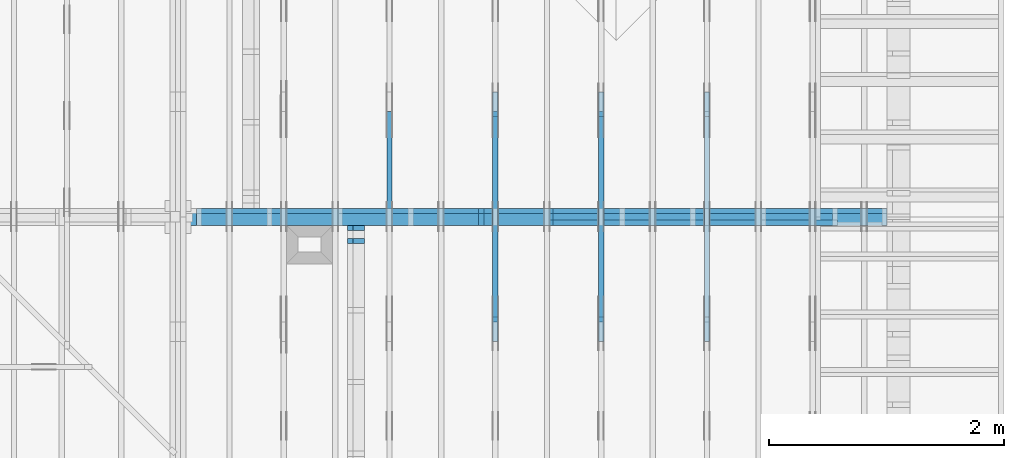
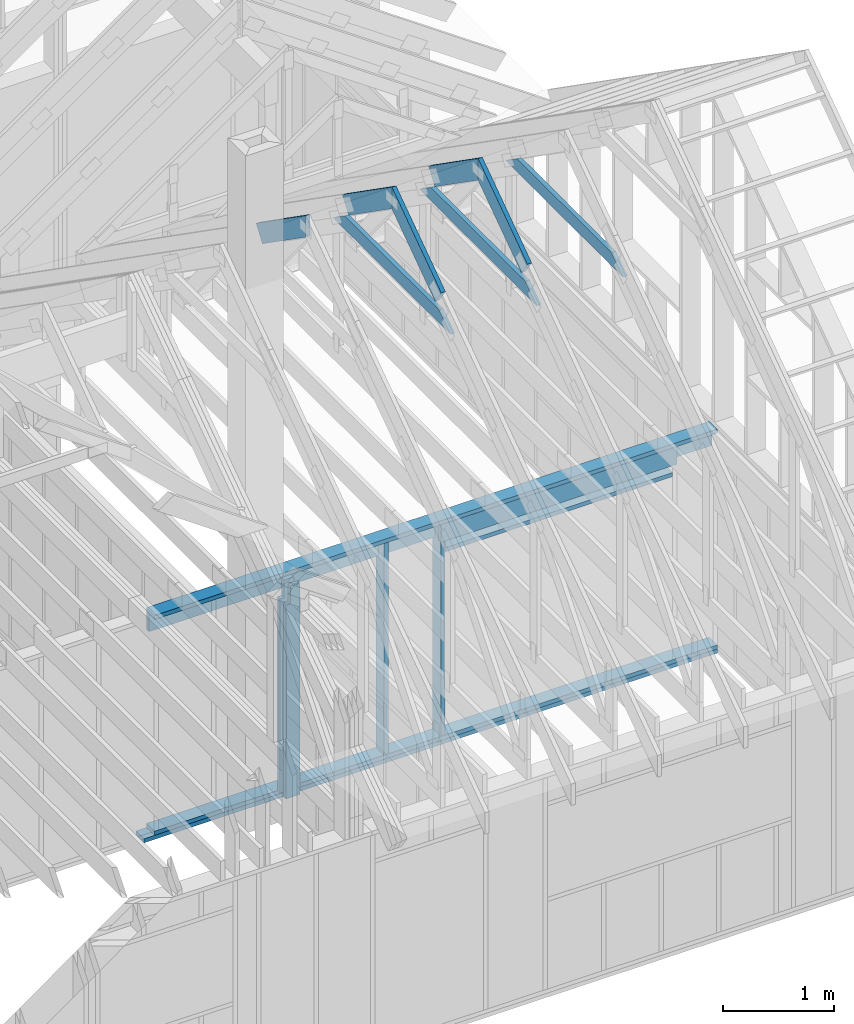
# One storey, part 24 of 70: 18 members, 6 elements without a shape of their own.
"""IFC2X3 building model written with IfcOpenShell, lengths in millimetres."""

from ifc_helpers import new_model, si_unit, frame, origin, origin_with_axes, origin_2d, place, context, project, spatial, faceted_brep, element, aggregate, save


model = new_model("IFC2X3")

# Units and contexts
model_context = context("Model", 3, precision=1e-05, world=origin())
plan_context = context("Plan", 2, precision=1e-05, world=origin_2d())
ifc_project = project(units=[si_unit("LENGTHUNIT", "METRE", prefix="MILLI"), si_unit("AREAUNIT", "SQUARE_METRE"), si_unit("VOLUMEUNIT", "CUBIC_METRE"), si_unit("SOLIDANGLEUNIT", "STERADIAN"), si_unit("PLANEANGLEUNIT", "RADIAN"), si_unit("MASSUNIT", "GRAM"), si_unit("TIMEUNIT", "SECOND"), si_unit("THERMODYNAMICTEMPERATUREUNIT", "DEGREE_CELSIUS"), si_unit("LUMINOUSINTENSITYUNIT", "LUMEN")], contexts=[model_context, plan_context])

# Site, building, storey
site_placement = place(None, origin_with_axes())
site = spatial("IfcSite", under=ifc_project, at=site_placement, CompositionType="ELEMENT")
building_placement = place(site_placement, origin_with_axes())
building = spatial("IfcBuilding", under=site, at=building_placement, Name="Layout 1", CompositionType="ELEMENT")
storey_placement = place(building_placement, origin_with_axes())
storey = spatial("IfcBuildingStorey", under=building, at=storey_placement, Name="Storey 1", CompositionType="ELEMENT", Elevation=0.0)

# Assembly, members
assembly_1_placement = place(storey_placement, frame((-48.55339059327651, 3927.500000000001, -2470.0), z_axis=(0.0, -1.0, 6.123031769111886e-17), x_axis=(1.0, 0.0, 0.0)))
assembly_1 = element("IfcElementAssembly", 1, at=assembly_1_placement, inside=storey, Name="VE8", AssemblyPlace="FACTORY", PredefinedType="NOTDEFINED")
member_1_placement = place(assembly_1_placement, frame((5979.999999999998, 2425.0, -145.0), z_axis=(0.0, 0.0, 1.0), x_axis=(1.0, 0.0, 0.0)))
member_1 = element("IfcMember", 2, at=member_1_placement, Name="P14", context=model_context, shape_type="Brep", body=[
    faceted_brep([(5873.553390593279, 45.0, 145.0), (0.0, 45.0, 145.0), (0.0, 0.0, 145.0), (5873.553390593279, 0.0, 145.0), (0.0, 45.0, 0.0), (5873.553390593279, 45.0, 7.192790801635497e-13), (5873.553390593279, 0.0, 7.192790801635497e-13), (0.0, 0.0, 0.0), (0.0, 0.0, 0.0), (8.878396065212235e-15, -1.0872540233210496e-30, 145.0), (1.4389124657412933e-14, 45.0, 145.0), (5.510728592200698e-15, 45.0, -3.3742366240998092e-31), (5873.553390593279, -1.0789186202453245e-12, 6.606252988048485e-29), (5873.553390593279, -1.0700402241801122e-12, 145.0), (1.6308810349815745e-30, 8.878396065212235e-15, 145.0), (0.0, 0.0, 0.0), (5873.553390593279, 45.0, 0.0), (5873.553390593279, 45.0, 145.0), (5873.553390593279, 0.0, 145.0), (5873.553390593279, 0.0, 0.0), (0.0, 45.0, 0.0), (-5.436270116605248e-31, 44.99999999999999, 145.0), (5873.553390593279, 44.99999999999963, 145.0), (5873.553390593279, 44.99999999999964, -2.208810534618833e-29)], [[[0, 1, 2, 3]], [[4, 5, 6, 7]], [[8, 9, 10, 11]], [[12, 13, 14, 15]], [[16, 17, 18, 19]], [[20, 21, 22, 23]]]),
])
member_2_placement = place(assembly_1_placement, frame((11853.553390593277, 90.0, -145.0), z_axis=(0.0, 0.0, 1.0), x_axis=(-1.0, 1.2246063538223773e-16, 0.0)))
member_2 = element("IfcMember", 3, at=member_2_placement, Name="P14", context=model_context, shape_type="Brep", body=[
    faceted_brep([(5873.553390593278, 45.00000000000072, 145.0), (0.0, 45.00000000000072, 145.0), (0.0, 0.0, 145.0), (5873.553390593278, 0.0, 145.0), (0.0, 45.00000000000072, 0.0), (5873.553390593278, 45.00000000000072, 7.192790801635496e-13), (5873.553390593278, 0.0, 7.192790801635496e-13), (0.0, 0.0, 0.0), (0.0, 0.0, 0.0), (8.878396065212235e-15, -1.0872540233210496e-30, 145.0), (1.4389124657412933e-14, 45.0, 145.0), (5.510728592200698e-15, 45.0, -3.3742366240998092e-31), (5873.553390593278, -1.0789186202453243e-12, 1.095692873241925e-28), (5873.553390593278, -1.070040224180112e-12, 145.0), (1.6308810349815745e-30, 8.878396065212235e-15, 145.0), (0.0, 0.0, 0.0), (5873.553390593278, 45.00000000000072, 0.0), (5873.553390593278, 45.00000000000072, 145.0), (5873.553390593278, 7.105427357601002e-13, 145.0), (5873.553390593278, 7.105427357601002e-13, 0.0), (0.0, 45.0, 0.0), (1.5777218104420236e-30, 44.99999999999999, 145.0), (5873.553390593278, 45.00000000000094, 145.0), (5873.553390593278, 45.000000000000945, 1.4199496293978212e-29)], [[[0, 1, 2, 3]], [[4, 5, 6, 7]], [[8, 9, 10, 11]], [[12, 13, 14, 15]], [[16, 17, 18, 19]], [[20, 21, 22, 23]]]),
])
member_3_placement = place(assembly_1_placement, frame((5979.999999999998, 2230.0, -145.0), z_axis=(0.0, 0.0, 1.0), x_axis=(1.0, 0.0, 0.0)))
member_3 = element("IfcMember", 4, at=member_3_placement, Name="L2", context=model_context, shape_type="Brep", body=[
    faceted_brep([(5873.553390593279, 195.0, 45.0), (0.0, 195.0, 45.0), (0.0, 0.0, 45.0), (5873.553390593279, 0.0, 45.0), (0.0, 195.0, 0.0), (5873.553390593279, 195.0, 7.192790801635497e-13), (5873.553390593279, 0.0, 7.192790801635497e-13), (0.0, 0.0, 0.0), (0.0, 0.0, 0.0), (2.755364296100349e-15, -3.3742366240998092e-31, 45.0), (2.6635188195636705e-14, 195.0, 45.0), (2.3879823899536357e-14, 195.0, -1.462169203776584e-30), (5873.553390593279, -1.0789186202453245e-12, 6.606252988048485e-29), (5873.553390593279, -1.0761632559492241e-12, 45.0), (5.061354936149714e-31, 2.755364296100349e-15, 45.0), (0.0, 0.0, 0.0), (5873.553390593279, 195.0, 0.0), (5873.553390593279, 195.0, 45.0), (5873.553390593279, 0.0, 45.0), (5873.553390593279, 0.0, 0.0), (0.0, 195.0, 0.0), (-1.6871183120499046e-31, 195.0, 45.0), (5873.553390593279, 194.99999999999963, 45.0), (5873.553390593279, 194.99999999999963, -2.208810534618833e-29)], [[[0, 1, 2, 3]], [[4, 5, 6, 7]], [[8, 9, 10, 11]], [[12, 13, 14, 15]], [[16, 17, 18, 19]], [[20, 21, 22, 23]]]),
])
member_4_placement = place(assembly_1_placement, frame((11853.553390593277, 45.0, -145.0), z_axis=(0.0, 0.0, 1.0), x_axis=(-1.0, 1.2246063538223773e-16, 0.0)))
member_4 = element("IfcMember", 5, at=member_4_placement, Name="P13", context=model_context, shape_type="Brep", body=[
    faceted_brep([(5980.000000000001, 45.00000000000001, 145.0), (0.0, 45.00000000000001, 145.0), (0.0, 0.0, 145.0), (5980.000000000001, 0.0, 145.0), (0.0, 45.00000000000001, 0.0), (5980.000000000001, 45.00000000000001, 7.323145995857817e-13), (5980.000000000001, 0.0, 7.323145995857817e-13), (0.0, 0.0, 0.0), (0.0, 0.0, 0.0), (8.878396065212235e-15, -1.0872540233210496e-30, 145.0), (1.4389124657641033e-14, 45.000000001862645, 145.0), (5.510728592428798e-15, 45.000000001862645, -3.3742366242394762e-31), (5980.000000000001, -1.0984718993786726e-12, 6.725978337372288e-29), (5980.000000000001, -1.0895935033134604e-12, 145.0), (1.6308810349815745e-30, 8.878396065212235e-15, 145.0), (0.0, 0.0, 0.0), (5980.000000000001, 45.00000000000001, 0.0), (5980.000000000001, 45.00000000000001, 145.0), (5980.000000000001, 0.0, 145.0), (5980.000000000001, 0.0, 0.0), (0.0, 45.000000001862645, 0.0), (-3.2311742677852644e-27, 45.00000000186264, 145.0), (5980.000000000001, 45.000000000000654, 145.0), (5980.000000000001, 45.00000000000067, 4.02319061662716e-29)], [[[0, 1, 2, 3]], [[4, 5, 6, 7]], [[8, 9, 10, 11]], [[12, 13, 14, 15]], [[16, 17, 18, 19]], [[20, 21, 22, 23]]]),
])
member_5_placement = place(assembly_1_placement, frame((8377.500000001819, 2425.0, -145.0), z_axis=(0.0, 0.0, 1.0), x_axis=(-1.836909530733566e-16, -1.0, 0.0)))
member_5 = element("IfcMember", 6, at=member_5_placement, Name="S42", context=model_context, shape_type="Brep", body=[
    faceted_brep([(0.0, 45.000000000029104, 45.0), (195.00000000186265, 45.000000000029104, 45.00000000000002), (195.00000000186265, 1.4551915228366852e-11, 45.00000000000002), (0.0, 1.4551915228366852e-11, 45.0), (195.00000000186265, 1.2732925824820995e-11, 0.0), (195.00000000186265, 1.2732925824820995e-11, 45.0), (195.00000000186265, 45.000000000027285, 45.0), (195.00000000186265, 45.000000000027285, 0.0), (2.755364296102131e-15, 1.4551915228366852e-11, 45.0), (8.878396065214018e-15, 1.4551915228366852e-11, 145.0), (1.43891246574165e-14, 45.000000000029104, 145.0), (8.26609288830461e-15, 45.000000000029104, 45.0), (2335.0, 1.4122996852940564e-11, 2.626280839091018e-29), (2335.0, 1.4131875249005776e-11, 145.0), (1.6308810349815745e-30, 1.4560793624432064e-11, 145.0), (5.061354936149714e-31, 1.4554670592662952e-11, 45.0), (195.00000000186265, 1.4518850856813305e-11, 45.0), (195.00000000186265, 1.4516095492517205e-11, 2.193253805685862e-30), (-1.6871183120499046e-31, 45.000000000027285, 45.0), (-5.436270116605248e-31, 45.00000000002728, 145.0), (2335.0, 45.000000000027136, 145.0), (2335.0, 45.00000000002714, -8.67746995743113e-30), (195.00000000186265, 45.00000000002727, -7.888609052210118e-31), (195.00000000186265, 45.00000000002727, 45.0), (2335.0, 45.00000000001455, 2.842170943040401e-14), (2335.0, 45.00000000001455, 145.0), (2335.0, 0.0, 145.0), (2335.0, 0.0, 2.842170943040401e-14), (2335.0, 45.00000000001455, 145.0), (0.0, 45.00000000001455, 145.0), (0.0, 1.4551915228366852e-11, 145.0), (2335.0, 1.4551915228366852e-11, 145.0), (195.00000000186265, 45.000000000027285, 2.3879823899764457e-14), (2335.0, 45.000000000027285, 2.859455836175251e-13), (2335.0, 0.0, 2.859455836175251e-13), (195.00000000186265, 0.0, 2.3879823899764457e-14)], [[[0, 1, 2, 3]], [[4, 5, 6, 7]], [[8, 9, 10, 11]], [[12, 13, 14, 15, 16, 17]], [[18, 19, 20, 21, 22, 23]], [[24, 25, 26, 27]], [[28, 29, 30, 31]], [[32, 33, 34, 35]]]),
])
member_6_placement = place(assembly_1_placement, frame((8967.500000003638, 2230.0, -45.0), z_axis=(0.0, 0.0, 1.0), x_axis=(1.0, 0.0, 0.0)))
member_6 = element("IfcMember", 7, at=member_6_placement, Name="L7", context=model_context, shape_type="Brep", body=[
    faceted_brep([(2465.0000000000437, 195.0, 45.0), (0.0, 195.0, 45.0), (1.8189894035458565e-12, 0.0, 45.0), (2465.000000000042, 0.0, 45.0), (0.0, 195.0, 0.0), (2465.0000000000437, 195.0, 3.0186546621722135e-13), (2465.000000000042, 0.0, 3.018654662172211e-13), (1.8189894035458565e-12, 0.0, 2.227545981117832e-28), (1.8189894035458565e-12, 0.0, 0.0), (1.821744767841957e-12, 2.5358754952779855e-29, 45.0), (2.7079277405486768e-14, 195.0, 45.0), (2.432391310938642e-14, 195.0, -1.4893609271789013e-30), (2465.000000000042, -4.5279819932583167e-13, 2.7724977594687237e-29), (2465.000000000042, -4.500428350297313e-13, 45.0), (1.8189894035458565e-12, 2.7553642961000147e-15, 45.0), (1.8189894035458565e-12, -3.341318971676748e-28, 2.0459002214312988e-44), (2465.000000000042, 195.0, -1.262177448353619e-28), (2465.000000000042, 195.0, 45.0), (2465.000000000042, 0.0, 45.0), (2465.000000000042, 0.0, 0.0), (0.0, 195.0, 0.0), (-1.6871183120499046e-31, 195.0, 45.0), (2465.0000000000437, 194.99999999999986, 45.0), (2465.0000000000437, 194.99999999999986, -9.466330862652142e-30)], [[[0, 1, 2, 3]], [[4, 5, 6, 7]], [[8, 9, 10, 11]], [[12, 13, 14, 15]], [[16, 17, 18, 19]], [[20, 21, 22, 23]]]),
])
member_7_placement = place(assembly_1_placement, frame((8967.500000003638, 2425.0, -145.0), z_axis=(0.0, 0.0, 1.0), x_axis=(-1.836909530733566e-16, -1.0, 0.0)))
member_7 = element("IfcMember", 8, at=member_7_placement, Name="S43", context=model_context, shape_type="Brep", body=[
    faceted_brep([(195.0, 1.8189894035458565e-12, 1.14050354233233e-25), (195.0, 1.8189894035458565e-12, 45.0), (195.0, 45.00000000001455, 45.0), (195.0, 45.00000000001455, 1.14050354233233e-25), (195.0, 1.8189894035458565e-12, 100.0), (195.0, 1.8189894035458565e-12, 145.0), (195.00000000000003, 45.00000000001455, 145.0), (195.0, 45.00000000001455, 100.0), (195.0, 45.00000000001455, 100.0), (0.0, 45.00000000001455, 100.0), (0.0, 1.8189894035458565e-12, 100.0), (195.0, 1.8189894035458565e-12, 100.0), (2335.0, 45.00000000001455, 145.0), (195.0, 45.00000000001455, 145.0), (195.0, 1.8189894035458565e-12, 145.0), (2335.0, 1.8189894035458565e-12, 145.0), (2335.0, 1.3900710281195688e-12, 2.626280839091018e-29), (2335.0, 1.398949424184781e-12, 145.0), (195.0, 1.7920480637617642e-12, 145.0), (195.0, 1.7892926994656638e-12, 100.0), (1.124745541366603e-30, 1.8251124353149684e-12, 100.0), (5.061354936149714e-31, 1.821744767841957e-12, 45.0), (195.0, 1.7859250319926523e-12, 45.0), (195.0, 1.783169667696552e-12, 2.193253805685817e-30), (0.0, 45.00000000001455, 45.0), (195.00000000186265, 45.00000000001455, 45.00000000000002), (195.00000000186265, 0.0, 45.00000000000002), (0.0, 0.0, 45.0), (2.755364296100349e-15, -3.3742366240998092e-31, 45.0), (6.123031769111886e-15, -7.498303609110687e-31, 100.0), (1.1633760361314367e-14, 45.00000000001455, 100.0), (8.26609288830283e-15, 45.00000000001455, 45.0), (-1.6871183120499046e-31, 45.00000000001455, 45.0), (-3.7491518045553436e-31, 45.000000000014545, 100.0), (195.0, 45.00000000001453, 100.0), (195.0, 45.00000000001453, 145.0), (2335.0, 45.0000000000144, 145.0), (2335.0, 45.00000000001441, -8.67746995743113e-30), (195.0, 45.00000000001454, -7.888609052210118e-31), (195.0, 45.00000000001454, 45.0), (2335.0, 45.00000000001455, 2.842170943040401e-14), (2335.0, 45.00000000001455, 145.0), (2335.0, 1.4551915228366852e-11, 145.0), (2335.0, 1.4551915228366852e-11, 0.0), (195.00000000186265, 45.00000000001455, 2.3879823899764457e-14), (2335.0, 45.00000000001455, 2.859455836175251e-13), (2335.0, 1.4551915228366852e-11, 2.859455836175251e-13), (195.00000000186265, 1.4551915228366852e-11, 2.3879823899764457e-14)], [[[0, 1, 2, 3]], [[4, 5, 6, 7]], [[8, 9, 10, 11]], [[12, 13, 14, 15]], [[16, 17, 18, 19, 20, 21, 22, 23]], [[24, 25, 26, 27]], [[28, 29, 30, 31]], [[32, 33, 34, 35, 36, 37, 38, 39]], [[40, 41, 42, 43]], [[44, 45, 46, 47]]]),
])
member_8_placement = place(assembly_1_placement, frame((11387.500000001834, 2154.9999999987776, -145.0), z_axis=(0.0, 0.0, 1.0), x_axis=(-1.0, 1.2246063538223773e-16, 0.0)))
member_8 = element("IfcMember", 9, at=member_8_placement, Name="S41", context=model_context, shape_type="Brep", body=[
    faceted_brep([(2375.0000000000146, 45.00000000001501, 145.0), (0.0, 45.00000000001501, 145.0), (0.0, 0.0, 145.0), (2375.0000000000146, 0.0, 145.0), (0.0, 45.00000000001501, 0.0), (2375.0000000000146, 45.00000000001501, 2.9084400903281637e-13), (2375.0000000000146, 0.0, 2.9084400903281637e-13), (0.0, 0.0, 0.0), (0.0, 0.0, 0.0), (8.878396065212235e-15, -1.0872540233210496e-30, 145.0), (1.4389124657414716e-14, 45.00000000001455, 145.0), (5.51072859220248e-15, 45.00000000001455, -3.3742366241009005e-31), (2375.0000000000146, -4.3626601354922457e-13, 5.455703137142988e-29), (2375.0000000000146, -4.2738761748401234e-13, 145.0), (1.6308810349815745e-30, 8.878396065212235e-15, 145.0), (0.0, 0.0, 0.0), (2375.0000000000146, 45.00000000001501, 0.0), (2375.0000000000146, 45.00000000001501, 145.0), (2375.0000000000146, 4.547473508864641e-13, 145.0), (2375.0000000000146, 4.547473508864641e-13, 0.0), (0.0, 45.00000000001455, 0.0), (1.5777218104420236e-30, 45.000000000014545, 145.0), (2375.0000000000146, 45.00000000001493, 145.0), (2375.0000000000146, 45.000000000014936, -4.733165431326071e-30)], [[[0, 1, 2, 3]], [[4, 5, 6, 7]], [[8, 9, 10, 11]], [[12, 13, 14, 15]], [[16, 17, 18, 19]], [[20, 21, 22, 23]]]),
])
aggregate(assembly_1, [member_1, member_2, member_3, member_4, member_5, member_6, member_7, member_8])

# Assembly, member
assembly_2_placement = place(storey_placement, frame((10250.0, 8000.0, -9.081170196248781e-13), z_axis=(-1.0, 1.836909530733566e-16, 6.123031769111886e-17), x_axis=(-1.836909530733566e-16, -1.0, 0.0)))
assembly_2 = element("IfcElementAssembly", 10, at=assembly_2_placement, inside=storey, Name="T3", AssemblyPlace="FACTORY", PredefinedType="TRUSS")
member_9_placement = place(assembly_2_placement, frame((5060.798502586593, 2964.999999998785, -45.0), z_axis=(0.0, 0.0, 1.0), x_axis=(-1.0, 1.2246063538223773e-16, 0.0)))
member_9 = element("IfcMember", 11, at=member_9_placement, Name="C1", context=model_context, shape_type="Brep", body=[
    faceted_brep([(2121.597005175296, 145.00000000000728, 45.0), (0.0, 145.00000000000728, 45.0), (207.08146097743884, 0.0, 45.0), (1914.5155441979737, 0.0, 45.0), (0.0, 145.00000000000728, 0.0), (2121.597005175296, 145.00000000000728, 2.5981211727881944e-13), (1914.5155441979737, 0.0, 2.3445278999165447e-13), (207.08146097743884, 0.0, 2.5359327287179227e-14), (207.08146097743878, -7.105427357601002e-14, 3.1554436208840472e-30), (207.08146097743878, -7.105427357601002e-14, 45.0), (1.4210854715202004e-14, 145.00000000000728, 45.0), (1.4210854715202004e-14, 145.00000000000728, 0.0), (1914.5155441979737, 7.26803319922997e-12, 4.8521444511629875e-31), (1914.5155441979737, 7.27078856352607e-12, 45.0), (207.08146097743884, 1.898228698049977e-15, 45.0), (207.08146097743884, -8.571355980503717e-16, 5.248268497299439e-32), (2121.597005175296, 145.00000000000728, 0.0), (2121.597005175296, 145.00000000000728, 45.0), (1914.515544197974, 7.389644451905042e-12, 45.0), (1914.515544197974, 7.389644451905042e-12, 1.262177448353619e-29), (0.0, 145.00000000000728, 0.0), (-1.6871183120499046e-31, 145.00000000000728, 45.0), (2121.597005175296, 145.00000000000713, 45.0), (2121.597005175296, 145.00000000000713, -7.888609052210118e-30)], [[[0, 1, 2, 3]], [[4, 5, 6, 7]], [[8, 9, 10, 11]], [[12, 13, 14, 15]], [[16, 17, 18, 19]], [[20, 21, 22, 23]]]),
])
aggregate(assembly_2, [member_9])

# Assembly, members
assembly_3_placement = place(storey_placement, frame((9350.0, 8000.0, -9.081170196248781e-13), z_axis=(-1.0, 1.836909530733566e-16, 6.123031769111886e-17), x_axis=(-1.836909530733566e-16, -1.0, 0.0)))
assembly_3 = element("IfcElementAssembly", 12, at=assembly_3_placement, inside=storey, Name="T3", AssemblyPlace="FACTORY", PredefinedType="TRUSS")
member_10_placement = place(assembly_3_placement, frame((5060.798502586593, 2964.999999998785, -45.0), z_axis=(0.0, 0.0, 1.0), x_axis=(-1.0, 1.2246063538223773e-16, 0.0)))
member_10 = element("IfcMember", 13, at=member_10_placement, Name="C1", context=model_context, shape_type="Brep", body=[
    faceted_brep([(2121.597005175296, 145.00000000000728, 45.0), (0.0, 145.00000000000728, 45.0), (207.08146097743884, 0.0, 45.0), (1914.5155441979737, 0.0, 45.0), (0.0, 145.00000000000728, 0.0), (2121.597005175296, 145.00000000000728, 2.5981211727881944e-13), (1914.5155441979737, 0.0, 2.3445278999165447e-13), (207.08146097743884, 0.0, 2.5359327287179227e-14), (207.08146097743878, -7.105427357601002e-14, 3.1554436208840472e-30), (207.08146097743878, -7.105427357601002e-14, 45.0), (1.4210854715202004e-14, 145.00000000000728, 45.0), (1.4210854715202004e-14, 145.00000000000728, 0.0), (1914.5155441979737, 7.26803319922997e-12, 4.8521444511629875e-31), (1914.5155441979737, 7.27078856352607e-12, 45.0), (207.08146097743884, 1.898228698049977e-15, 45.0), (207.08146097743884, -8.571355980503717e-16, 5.248268497299439e-32), (2121.597005175296, 145.00000000000728, 0.0), (2121.597005175296, 145.00000000000728, 45.0), (1914.515544197974, 7.389644451905042e-12, 45.0), (1914.515544197974, 7.389644451905042e-12, 1.262177448353619e-29), (0.0, 145.00000000000728, 0.0), (-1.6871183120499046e-31, 145.00000000000728, 45.0), (2121.597005175296, 145.00000000000713, 45.0), (2121.597005175296, 145.00000000000713, -7.888609052210118e-30)], [[[0, 1, 2, 3]], [[4, 5, 6, 7]], [[8, 9, 10, 11]], [[12, 13, 14, 15]], [[16, 17, 18, 19]], [[20, 21, 22, 23]]]),
])
member_11_placement = place(assembly_3_placement, frame((3888.1525949105694, 3641.0955042035366, -45.00000000000001), z_axis=(0.0, 0.0, 1.0), x_axis=(0.8191520442889916, -0.5735764363510465, 0.0)))
member_11 = element("IfcMember", 14, at=member_11_placement, Name="T18", context=model_context, shape_type="Brep", body=[
    faceted_brep([(1091.5642005560503, 194.99999999996362, 45.0), (0.0, 194.99999999996362, 45.0), (136.54046995208614, 0.0, 45.0), (1091.5642005561149, 0.0, 45.0), (0.0, 194.99999999996362, 0.0), (1091.5642005560503, 194.99999999996362, 1.336736455605983e-13), (1091.5642005561149, 0.0, 1.336736455606062e-13), (136.54046995208614, 0.0, 1.6720832705721806e-14), (136.54046995208614, -2.842170943040401e-14, 3.0619884913871384e-31), (136.54046995208614, -2.842170943040401e-14, 45.0), (1.4210854715202004e-14, 195.00000000170263, 45.0), (1.4210854715202004e-14, 195.00000000170263, -5.932810329456638e-31), (1091.5642005561149, 2.0525182992035534e-09, 1.2934457505131873e-29), (1091.5642005561149, 2.0525210545678495e-09, 45.0), (136.54046995208614, -2.3668346958569874e-14, 45.0), (136.54046995208614, -2.6423711254670222e-14, 1.6179322347011683e-30), (1091.5642005561149, 194.99999999996362, 3.950615413346827e-27), (1091.5642005561149, 194.99999999996362, 45.0), (1091.5642005561149, 2.052729541901499e-09, 45.0), (1091.5642005561149, 2.052729541901499e-09, 0.0), (0.0, 195.00000000170257, 0.0), (0.0, 195.00000000170257, 45.0), (1091.5642005560503, 194.9999999999637, 45.0), (1091.5642005560503, 194.9999999999637, 6.310887241768095e-30)], [[[0, 1, 2, 3]], [[4, 5, 6, 7]], [[8, 9, 10, 11]], [[12, 13, 14, 15]], [[16, 17, 18, 19]], [[20, 21, 22, 23]]]),
])
member_12_placement = place(assembly_3_placement, frame((3217.690358731264, 3015.0000000002183, -45.00000000000001), z_axis=(0.0, 0.0, 1.0), x_axis=(0.8191520442889918, 0.5735764363510462, 0.0)))
member_12 = element("IfcMember", 15, at=member_12_placement, Name="T18", context=model_context, shape_type="Brep", body=[
    faceted_brep([(1091.564200553914, 194.99999999865213, 45.0), (0.0, 194.99999999865213, 45.0), (1.6370904631912708e-10, 7.557900971733034e-10, 45.0), (955.0237306039635, 7.557900971733034e-10, 45.0), (0.0, 194.99999999865213, 0.0), (1091.564200553914, 194.99999999865213, 1.3367364556033665e-13), (955.0237306039635, 7.557900971733034e-10, 1.169528128548764e-13), (1.6370904631912708e-10, 7.557900971733034e-10, 2.004791383006049e-26), (1.6370904631912732e-10, 7.557900971733033e-10, -1.4349296274686127e-41), (1.6371180168342342e-10, 7.557900971733033e-10, 45.0), (6.660321774678196e-14, 194.99999999996407, 45.0), (6.384785345068161e-14, 194.99999999996407, -3.909424350681179e-30), (955.0237306039635, -1.5956987698560245e-13, 9.770514261762543e-30), (955.0237306039635, -1.568145126895021e-13, 45.0), (1.6370904631912708e-10, 7.557928525375995e-10, 45.0), (1.6370904631912708e-10, 7.557900971733034e-10, 0.0), (1091.564200553914, 194.99999999865213, 0.0), (1091.564200553914, 194.99999999865213, 45.0), (955.0237306039635, -5.684341886080802e-14, 45.0), (955.0237306039635, -5.684341886080802e-14, -6.310887241768095e-30), (0.0, 194.99999999996407, 0.0), (0.0, 194.99999999996407, 45.0), (1091.564200553914, 194.99999999865202, 45.0), (1091.564200553914, 194.99999999865202, -6.310887241768095e-30)], [[[0, 1, 2, 3]], [[4, 5, 6, 7]], [[8, 9, 10, 11]], [[12, 13, 14, 15]], [[16, 17, 18, 19]], [[20, 21, 22, 23]]]),
])
aggregate(assembly_3, [member_10, member_11, member_12])

assembly_4_placement = place(storey_placement, frame((8450.0, 8000.0, -9.081170196248781e-13), z_axis=(-1.0, 1.836909530733566e-16, 6.123031769111886e-17), x_axis=(-1.836909530733566e-16, -1.0, 0.0)))
assembly_4 = element("IfcElementAssembly", 16, at=assembly_4_placement, inside=storey, Name="T3", AssemblyPlace="FACTORY", PredefinedType="TRUSS")
member_13_placement = place(assembly_4_placement, frame((5060.798502586593, 2964.999999998785, -45.0), z_axis=(0.0, 0.0, 1.0), x_axis=(-1.0, 1.2246063538223773e-16, 0.0)))
member_13 = element("IfcMember", 17, at=member_13_placement, Name="C1", context=model_context, shape_type="Brep", body=[
    faceted_brep([(2121.597005175296, 145.00000000000728, 45.0), (0.0, 145.00000000000728, 45.0), (207.08146097743884, 0.0, 45.0), (1914.5155441979737, 0.0, 45.0), (0.0, 145.00000000000728, 0.0), (2121.597005175296, 145.00000000000728, 2.5981211727881944e-13), (1914.5155441979737, 0.0, 2.3445278999165447e-13), (207.08146097743884, 0.0, 2.5359327287179227e-14), (207.08146097743878, -7.105427357601002e-14, 3.1554436208840472e-30), (207.08146097743878, -7.105427357601002e-14, 45.0), (1.4210854715202004e-14, 145.00000000000728, 45.0), (1.4210854715202004e-14, 145.00000000000728, 0.0), (1914.5155441979737, 7.26803319922997e-12, 4.8521444511629875e-31), (1914.5155441979737, 7.27078856352607e-12, 45.0), (207.08146097743884, 1.898228698049977e-15, 45.0), (207.08146097743884, -8.571355980503717e-16, 5.248268497299439e-32), (2121.597005175296, 145.00000000000728, 0.0), (2121.597005175296, 145.00000000000728, 45.0), (1914.515544197974, 7.389644451905042e-12, 45.0), (1914.515544197974, 7.389644451905042e-12, 1.262177448353619e-29), (0.0, 145.00000000000728, 0.0), (-1.6871183120499046e-31, 145.00000000000728, 45.0), (2121.597005175296, 145.00000000000713, 45.0), (2121.597005175296, 145.00000000000713, -7.888609052210118e-30)], [[[0, 1, 2, 3]], [[4, 5, 6, 7]], [[8, 9, 10, 11]], [[12, 13, 14, 15]], [[16, 17, 18, 19]], [[20, 21, 22, 23]]]),
])
member_14_placement = place(assembly_4_placement, frame((3888.1525949105694, 3641.0955042035366, -45.00000000000001), z_axis=(0.0, 0.0, 1.0), x_axis=(0.8191520442889916, -0.5735764363510465, 0.0)))
member_14 = element("IfcMember", 18, at=member_14_placement, Name="T18", context=model_context, shape_type="Brep", body=[
    faceted_brep([(1091.5642005560503, 194.99999999996362, 45.0), (0.0, 194.99999999996362, 45.0), (136.54046995208614, 0.0, 45.0), (1091.5642005561149, 0.0, 45.0), (0.0, 194.99999999996362, 0.0), (1091.5642005560503, 194.99999999996362, 1.336736455605983e-13), (1091.5642005561149, 0.0, 1.336736455606062e-13), (136.54046995208614, 0.0, 1.6720832705721806e-14), (136.54046995208614, -2.842170943040401e-14, 3.0619884913871384e-31), (136.54046995208614, -2.842170943040401e-14, 45.0), (1.4210854715202004e-14, 195.00000000170263, 45.0), (1.4210854715202004e-14, 195.00000000170263, -5.932810329456638e-31), (1091.5642005561149, 2.0525182992035534e-09, 1.2934457505131873e-29), (1091.5642005561149, 2.0525210545678495e-09, 45.0), (136.54046995208614, -2.3668346958569874e-14, 45.0), (136.54046995208614, -2.6423711254670222e-14, 1.6179322347011683e-30), (1091.5642005561149, 194.99999999996362, 3.950615413346827e-27), (1091.5642005561149, 194.99999999996362, 45.0), (1091.5642005561149, 2.052729541901499e-09, 45.0), (1091.5642005561149, 2.052729541901499e-09, 0.0), (0.0, 195.00000000170257, 0.0), (0.0, 195.00000000170257, 45.0), (1091.5642005560503, 194.9999999999637, 45.0), (1091.5642005560503, 194.9999999999637, 6.310887241768095e-30)], [[[0, 1, 2, 3]], [[4, 5, 6, 7]], [[8, 9, 10, 11]], [[12, 13, 14, 15]], [[16, 17, 18, 19]], [[20, 21, 22, 23]]]),
])
member_15_placement = place(assembly_4_placement, frame((3217.690358731264, 3015.0000000002183, -45.00000000000001), z_axis=(0.0, 0.0, 1.0), x_axis=(0.8191520442889918, 0.5735764363510462, 0.0)))
member_15 = element("IfcMember", 19, at=member_15_placement, Name="T18", context=model_context, shape_type="Brep", body=[
    faceted_brep([(1091.564200553914, 194.99999999865213, 45.0), (0.0, 194.99999999865213, 45.0), (1.6370904631912708e-10, 7.557900971733034e-10, 45.0), (955.0237306039635, 7.557900971733034e-10, 45.0), (0.0, 194.99999999865213, 0.0), (1091.564200553914, 194.99999999865213, 1.3367364556033665e-13), (955.0237306039635, 7.557900971733034e-10, 1.169528128548764e-13), (1.6370904631912708e-10, 7.557900971733034e-10, 2.004791383006049e-26), (1.6370904631912732e-10, 7.557900971733033e-10, -1.4349296274686127e-41), (1.6371180168342342e-10, 7.557900971733033e-10, 45.0), (6.660321774678196e-14, 194.99999999996407, 45.0), (6.384785345068161e-14, 194.99999999996407, -3.909424350681179e-30), (955.0237306039635, -1.5956987698560245e-13, 9.770514261762543e-30), (955.0237306039635, -1.568145126895021e-13, 45.0), (1.6370904631912708e-10, 7.557928525375995e-10, 45.0), (1.6370904631912708e-10, 7.557900971733034e-10, 0.0), (1091.564200553914, 194.99999999865213, 0.0), (1091.564200553914, 194.99999999865213, 45.0), (955.0237306039635, -5.684341886080802e-14, 45.0), (955.0237306039635, -5.684341886080802e-14, -6.310887241768095e-30), (0.0, 194.99999999996407, 0.0), (0.0, 194.99999999996407, 45.0), (1091.564200553914, 194.99999999865202, 45.0), (1091.564200553914, 194.99999999865202, -6.310887241768095e-30)], [[[0, 1, 2, 3]], [[4, 5, 6, 7]], [[8, 9, 10, 11]], [[12, 13, 14, 15]], [[16, 17, 18, 19]], [[20, 21, 22, 23]]]),
])
aggregate(assembly_4, [member_13, member_14, member_15])

# Assembly, member
assembly_5_placement = place(storey_placement, frame((7550.000000000001, 8000.0, -9.081170196248781e-13), z_axis=(-1.0, 1.836909530733566e-16, 6.123031769111886e-17), x_axis=(-1.836909530733566e-16, -1.0, 0.0)))
assembly_5 = element("IfcElementAssembly", 20, at=assembly_5_placement, inside=storey, Name="T3", AssemblyPlace="FACTORY", PredefinedType="TRUSS")
member_16_placement = place(assembly_5_placement, frame((3217.690358731264, 3015.0000000002183, -45.00000000000001), z_axis=(0.0, 0.0, 1.0), x_axis=(0.8191520442889918, 0.5735764363510462, 0.0)))
member_16 = element("IfcMember", 21, at=member_16_placement, Name="T18", context=model_context, shape_type="Brep", body=[
    faceted_brep([(1091.564200553914, 194.99999999865213, 45.0), (0.0, 194.99999999865213, 45.0), (1.6370904631912708e-10, 7.557900971733034e-10, 45.0), (955.0237306039635, 7.557900971733034e-10, 45.0), (0.0, 194.99999999865213, 0.0), (1091.564200553914, 194.99999999865213, 1.3367364556033665e-13), (955.0237306039635, 7.557900971733034e-10, 1.169528128548764e-13), (1.6370904631912708e-10, 7.557900971733034e-10, 2.004791383006049e-26), (1.6370904631912732e-10, 7.557900971733033e-10, -1.4349296274686127e-41), (1.6371180168342342e-10, 7.557900971733033e-10, 45.0), (6.660321774678196e-14, 194.99999999996407, 45.0), (6.384785345068161e-14, 194.99999999996407, -3.909424350681179e-30), (955.0237306039635, -1.5956987698560245e-13, 9.770514261762543e-30), (955.0237306039635, -1.568145126895021e-13, 45.0), (1.6370904631912708e-10, 7.557928525375995e-10, 45.0), (1.6370904631912708e-10, 7.557900971733034e-10, 0.0), (1091.564200553914, 194.99999999865213, 0.0), (1091.564200553914, 194.99999999865213, 45.0), (955.0237306039635, -5.684341886080802e-14, 45.0), (955.0237306039635, -5.684341886080802e-14, -6.310887241768095e-30), (0.0, 194.99999999996407, 0.0), (0.0, 194.99999999996407, 45.0), (1091.564200553914, 194.99999999865202, 45.0), (1091.564200553914, 194.99999999865202, -6.310887241768095e-30)], [[[0, 1, 2, 3]], [[4, 5, 6, 7]], [[8, 9, 10, 11]], [[12, 13, 14, 15]], [[16, 17, 18, 19]], [[20, 21, 22, 23]]]),
])
aggregate(assembly_5, [member_16])

# Assembly, members
assembly_6_placement = place(storey_placement, frame((7359.197265625001, 195.0, -2470.0), z_axis=(1.0, -6.123031769111886e-17, 6.123031769111886e-17), x_axis=(6.123031769111886e-17, 1.0, 0.0)))
assembly_6 = element("IfcElementAssembly", 22, at=assembly_6_placement, inside=storey, Name="VE10", AssemblyPlace="FACTORY", PredefinedType="NOTDEFINED")
member_17_placement = place(assembly_6_placement, frame((3687.5, 2425.0000000000005, -145.0), z_axis=(0.0, 0.0, 1.0), x_axis=(-1.836909530733566e-16, -1.0, 0.0)))
member_17 = element("IfcMember", 23, at=member_17_placement, Name="S42", context=model_context, shape_type="Brep", body=[
    faceted_brep([(0.0, 45.0, 45.0), (195.00000000186265, 45.0, 45.00000000000002), (195.0000000018631, 0.0, 45.00000000000002), (4.547473508864641e-13, 0.0, 45.0), (195.0000000018631, 0.0, 0.0), (195.0000000018631, 0.0, 45.0), (195.00000000186267, 44.99999999999999, 45.0), (195.00000000186267, 44.99999999999999, -1.5777218104420236e-30), (4.575027151825645e-13, 2.658238250588413e-29, 45.0), (4.636257469516764e-13, 8.565434363007109e-29, 145.0), (2.948815779231506e-14, 45.0, 145.0), (2.3365126023203175e-14, 45.0, 45.0), (2335.0, -4.2891837542628763e-13, 2.626280839091018e-29), (2335.0, -4.200399793610754e-13, 145.0), (4.547473508864641e-13, 8.878396065212152e-15, 145.0), (4.547473508864641e-13, 2.7553642961002652e-15, 45.0), (195.0000000018631, -3.306437155354642e-14, 45.0), (195.0000000018631, -3.581973584964677e-14, 2.193253805685831e-30), (-1.6871183120499046e-31, 45.0, 45.0), (-5.436270116605248e-31, 44.99999999999999, 145.0), (2335.0, 44.99999999999985, 145.0), (2335.0, 44.99999999999986, -8.67746995743113e-30), (195.00000000186265, 44.999999999999986, -7.888609052210118e-31), (195.00000000186265, 44.999999999999986, 45.0), (2335.0, 45.000000000000455, 2.842170943040401e-14), (2335.0, 45.000000000000455, 145.0), (2335.0, 4.547473508864641e-13, 145.0), (2335.0, 4.547473508864641e-13, 0.0), (2335.0, 45.000000000000455, 145.0), (0.0, 45.000000000000455, 145.0), (4.547473508864641e-13, 0.0, 145.0), (2335.0, 0.0, 145.0), (195.00000000186265, 45.0, 2.3879823899764457e-14), (2335.0, 45.0, 2.859455836175251e-13), (2335.0, 4.547473508864641e-13, 2.859455836175251e-13), (195.0000000018631, 4.547473508864641e-13, 2.3879823899764514e-14)], [[[0, 1, 2, 3]], [[4, 5, 6, 7]], [[8, 9, 10, 11]], [[12, 13, 14, 15, 16, 17]], [[18, 19, 20, 21, 22, 23]], [[24, 25, 26, 27]], [[28, 29, 30, 31]], [[32, 33, 34, 35]]]),
])
member_18_placement = place(assembly_6_placement, frame((3577.500000001819, 2425.0, -145.0), z_axis=(0.0, 0.0, 1.0), x_axis=(-1.836909530733566e-16, -1.0, 0.0)))
member_18 = element("IfcMember", 24, at=member_18_placement, Name="S42", context=model_context, shape_type="Brep", body=[
    faceted_brep([(0.0, 45.00000000001455, 45.0), (195.00000000186265, 45.00000000001455, 45.00000000000002), (195.00000000186265, 0.0, 45.00000000000002), (0.0, 0.0, 45.0), (195.00000000186265, 1.3642420526593924e-12, 0.0), (195.00000000186265, 1.3642420526593924e-12, 45.0), (195.00000000186265, 45.00000000001455, 45.0), (195.00000000186265, 45.00000000001455, 0.0), (2.755364296100349e-15, -3.3742366240998092e-31, 45.0), (8.878396065212235e-15, -1.0872540233210496e-30, 145.0), (1.4389124657414716e-14, 45.00000000001455, 145.0), (8.26609288830283e-15, 45.00000000001455, 45.0), (2335.0, -4.2891837542628763e-13, 2.626280839091018e-29), (2335.0, -4.200399793610754e-13, 145.0), (1.6308810349815745e-30, 8.878396065212235e-15, 145.0), (5.061354936149714e-31, 2.755364296100349e-15, 45.0), (195.00000000186265, -3.306437155354634e-14, 45.0), (195.00000000186265, -3.5819735849646686e-14, 2.193253805685826e-30), (-1.6871183120499046e-31, 45.00000000001455, 45.0), (-5.436270116605248e-31, 45.000000000014545, 145.0), (2335.0, 45.0000000000144, 145.0), (2335.0, 45.00000000001441, -8.67746995743113e-30), (195.00000000186265, 45.00000000001454, -7.888609052210118e-31), (195.00000000186265, 45.00000000001454, 45.0), (2335.0, 45.00000000001501, 2.842170943040401e-14), (2335.0, 45.00000000001501, 145.0), (2335.0, 1.5006662579253316e-11, 145.0), (2335.0, 1.5006662579253316e-11, 0.0), (2335.0, 45.00000000001501, 145.0), (0.0, 45.00000000001501, 145.0), (0.0, 0.0, 145.0), (2335.0, 0.0, 145.0), (195.00000000186265, 45.00000000001455, 2.3879823899764457e-14), (2335.0, 45.00000000001455, 2.859455836175251e-13), (2335.0, 1.5006662579253316e-11, 2.859455836175251e-13), (195.00000000186265, 1.5006662579253316e-11, 2.3879823899764457e-14)], [[[0, 1, 2, 3]], [[4, 5, 6, 7]], [[8, 9, 10, 11]], [[12, 13, 14, 15, 16, 17]], [[18, 19, 20, 21, 22, 23]], [[24, 25, 26, 27]], [[28, 29, 30, 31]], [[32, 33, 34, 35]]]),
])
aggregate(assembly_6, [member_17, member_18])

save(model, "model.ifc")
